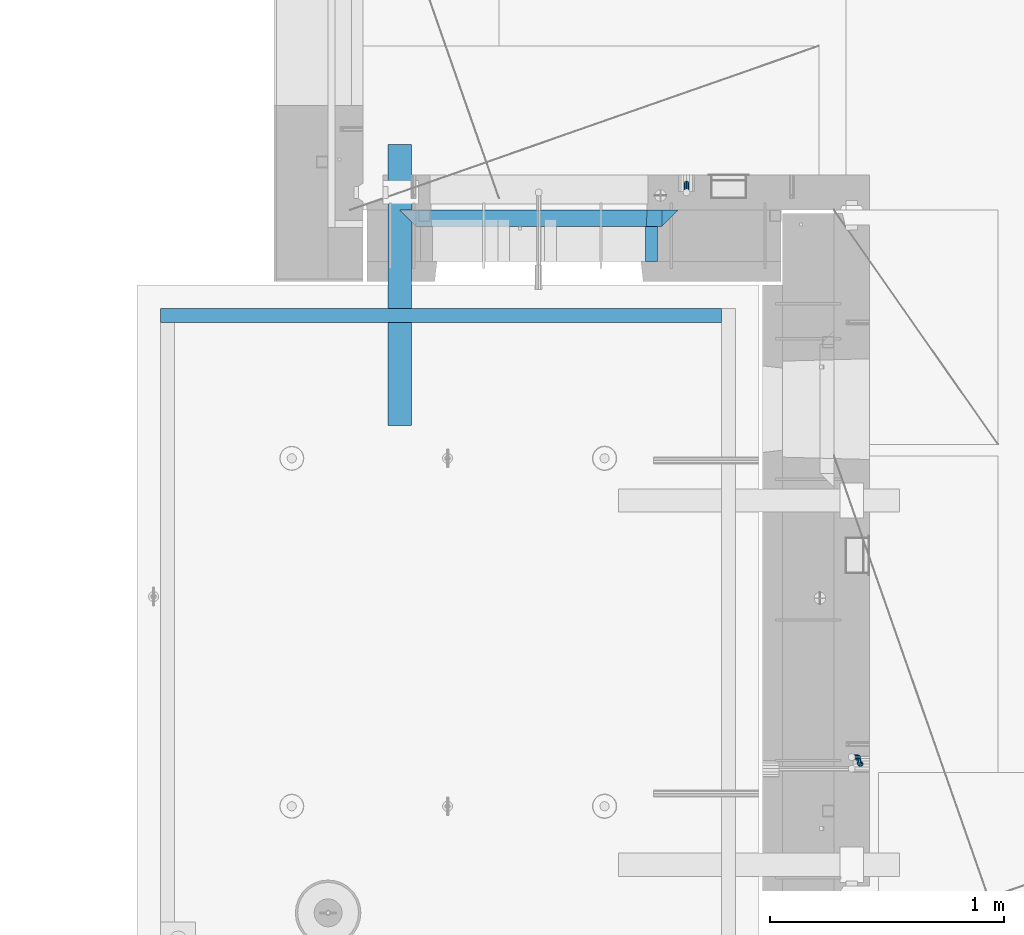
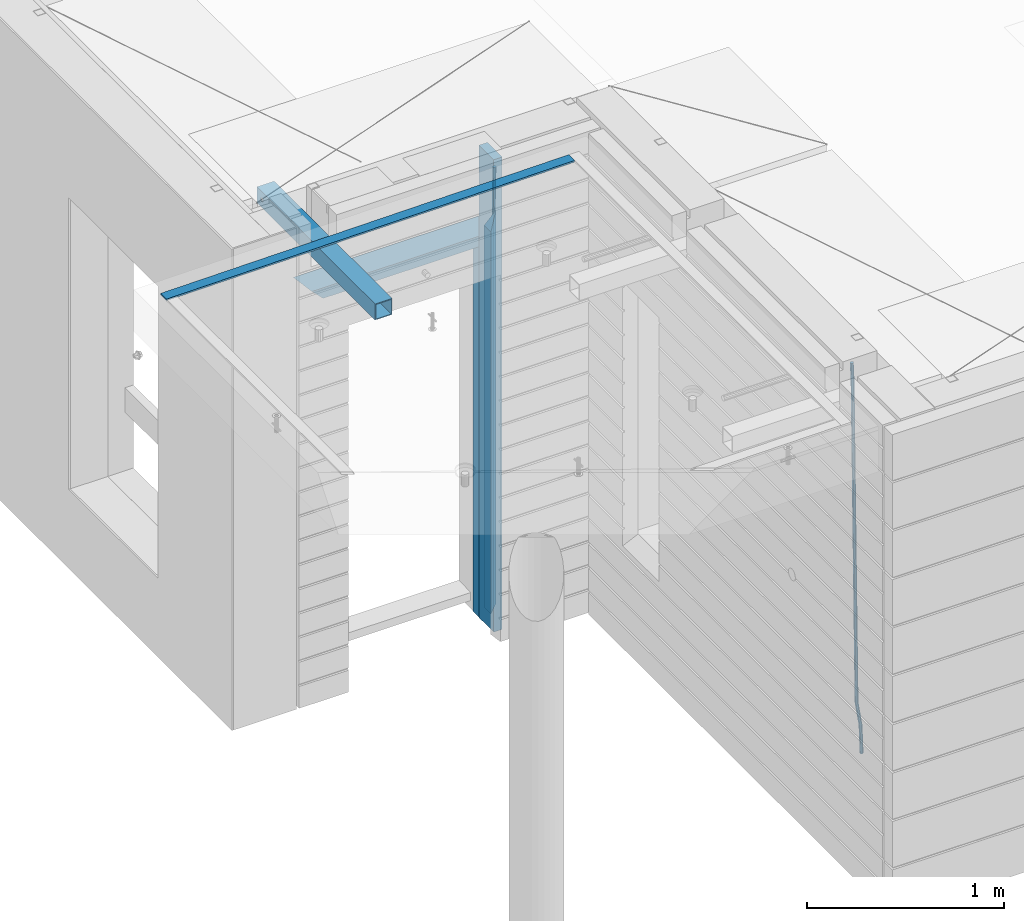
# One storey, part 94 of 350: 9 beams, 4 elements without a shape of their own.
"""IFC2X3 building model written with IfcOpenShell, lengths in millimetres."""

from ifc_helpers import new_model, si_unit, frame, origin_with_axes, place, context, subcontext, project, spatial, faceted_brep, material, type_object, element, aggregate, save


model = new_model("IFC2X3")

# Units and contexts
model_context = context("Model", 3, precision=1e-05, world=origin_with_axes())
body_context = subcontext(model_context, "Body", "Model", "MODEL_VIEW")
ifc_project = project(units=[si_unit("LENGTHUNIT", "METRE", prefix="MILLI"), si_unit("AREAUNIT", "SQUARE_METRE"), si_unit("VOLUMEUNIT", "CUBIC_METRE"), si_unit("MASSUNIT", "GRAM", prefix="KILO"), si_unit("TIMEUNIT", "SECOND"), si_unit("PLANEANGLEUNIT", "RADIAN"), si_unit("SOLIDANGLEUNIT", "STERADIAN"), si_unit("THERMODYNAMICTEMPERATUREUNIT", "DEGREE_CELSIUS"), si_unit("LUMINOUSINTENSITYUNIT", "LUMEN")], contexts=[model_context])

# Site, building, storey
site_placement = place(None, origin_with_axes())
site = spatial("IfcSite", under=ifc_project, at=site_placement, CompositionType="ELEMENT")
building_placement = place(site_placement, origin_with_axes())
building = spatial("IfcBuilding", under=site, at=building_placement, CompositionType="ELEMENT")
storey_placement = place(building_placement, origin_with_axes())
storey = spatial("IfcBuildingStorey", under=building, at=storey_placement, Name="2", CompositionType="ELEMENT", Elevation=0.0)

# Assembly, beams
assembly_1_placement = place(storey_placement, origin_with_axes())
assembly_1 = element("IfcElementAssembly", 1, at=assembly_1_placement, inside=storey, AssemblyPlace="NOTDEFINED", PredefinedType="REINFORCEMENT_UNIT")
ifc_material_1 = material(Name="CONCRETE/C25/30")
beam_type_1 = type_object("IfcBeamType", PredefinedType="NOTDEFINED")
beam_1_placement = place(assembly_1_placement, frame((8155.00084638596, 10914.9999977209, 87160.0), z_axis=(0.0, 0.0, -1.0), x_axis=(1.0, 0.0, 0.0)))
beam_1 = element("IfcBeam", 2, at=beam_1_placement, type_object=beam_type_1, material=ifc_material_1, Name="SK", context=body_context, shape_type="Brep", body=[
    faceted_brep([(70.0000000000164, -35.0, 35.0), (70.0000000000164, 35.0, 35.0), (0.0, -35.0, -35.0), (1189.99771118164, -35.0, -35.0), (1119.99771118163, -35.0, 35.0), (1119.99771118163, 35.0, 35.0)], [[[0, 1, 2]], [[0, 2, 3, 4]], [[1, 0, 4, 5]], [[2, 1, 5, 3]], [[4, 3, 5]]]),
])
beam_2_placement = place(assembly_1_placement, frame((8225.00084638596, 10914.9999988604, 87090.0), z_axis=(0.0, 0.0, -1.0), x_axis=(1.0, 0.0, 0.0)))
beam_2 = element("IfcBeam", 3, at=beam_2_placement, type_object=beam_type_1, material=ifc_material_1, Name="SK", context=body_context, shape_type="Brep", body=[
    faceted_brep([(0.0, -35.0, -35.0), (64.051765297294, -34.9999988604341, 29.0540541156515), (65.9436571275874, 34.9999988604341, 30.9459459459467), (0.0, 35.0, -35.0), (1049.99771118164, -34.9999988604341, -35.0), (985.943657065987, -34.9999988604341, 29.0540541156515), (984.051765235694, 34.9999988604341, 30.9459459459467), (1049.99771118164, 34.9999988604341, -35.0)], [[[0, 1, 2, 3]], [[1, 0, 4, 5]], [[2, 1, 5, 6]], [[3, 2, 6, 7]], [[0, 3, 7, 4]], [[6, 5, 4, 7]]]),
])
beam_3_placement = place(assembly_1_placement, frame((9309.9985575676, 10914.9999977209, 87195.0), z_axis=(-1.0, 3.00000001838171e-08, 0.0), x_axis=(0.0, 0.0, -1.0)))
beam_3 = element("IfcBeam", 4, at=beam_3_placement, type_object=beam_type_1, material=ifc_material_1, Name="SK", context=body_context, shape_type="Brep", body=[
    faceted_brep([(2440.0, -35.0, 35.0), (2440.0, -35.0, -35.0), (2440.0, 35.0, 35.0), (0.0, -35.0, -35.0), (70.0000000000164, 35.0, 35.0), (70.0000000000164, -35.0, 35.0)], [[[0, 1, 2]], [[2, 1, 3, 4]], [[0, 2, 4, 5]], [[1, 0, 5, 3]], [[5, 4, 3]]]),
])
beam_4_placement = place(assembly_1_placement, frame((9239.9985575676, 10914.9999988604, 87125.0), z_axis=(-1.0, 3.00000001838171e-08, 0.0), x_axis=(0.0, 0.0, -1.0)))
beam_4 = element("IfcBeam", 5, at=beam_4_placement, type_object=beam_type_1, material=ifc_material_1, Name="SK", context=body_context, shape_type="Brep", body=[
    faceted_brep([(2370.0, -34.9999988604341, -35.0), (2370.0, 34.9999988604341, -35.0), (2370.0, 34.9999988604341, 30.9459459459467), (2370.0, -34.9999988604341, 29.0540541156515), (0.0, -35.0, -35.0), (0.0, 35.0, -35.0), (65.9459459459467, 34.9999988604341, 30.9459459459467), (64.0540541156515, -34.9999988604341, 29.0540541156533)], [[[0, 1, 2, 3]], [[4, 5, 1, 0]], [[2, 1, 5, 6]], [[3, 2, 6, 7]], [[0, 3, 7, 4]], [[6, 5, 4, 7]]]),
])
ifc_material_2 = material(Name="TIMBER")
beam_type_2 = type_object("IfcBeamType", Name="50X150", PredefinedType="NOTDEFINED")
beam_5_placement = place(assembly_1_placement, frame((9229.9985575676, 10804.9999977209, 87690.0), z_axis=(-1.0, 3.00000001838171e-08, 0.0), x_axis=(0.0, 0.0, -1.0)))
beam_5 = element("IfcBeam", 6, at=beam_5_placement, type_object=beam_type_2, material=ifc_material_2, ObjectType="50X150", context=body_context, shape_type="Brep", body=[
    faceted_brep([(0.0, 75.0, -25.0), (1.81898940354586e-12, 75.0, 25.0), (2930.0, 75.0, 25.0), (2930.0, 75.0, -25.0), (1.81898940354586e-12, -75.0000000000009, 25.0), (2930.0, -75.0, 25.0), (0.0, -75.0, -25.0), (2930.0, -75.0, -25.0)], [[[0, 1, 2, 3]], [[1, 4, 5, 2]], [[4, 6, 7, 5]], [[6, 0, 3, 7]], [[5, 7, 3, 2]], [[6, 4, 1, 0]]]),
])
ifc_material_3 = material()
beam_type_3 = type_object("IfcBeamType", Name="D20", PredefinedType="NOTDEFINED")
beam_6_placement = place(assembly_1_placement, frame((9379.9982799665, 11065.0, 85790.0), z_axis=(0.00020576299992186, -0.999642804629538, -0.0267249099901004), x_axis=(-4.30000201928125e-08, -0.0267249099948059, 0.999642825806181)))
beam_6 = element("IfcBeam", 7, at=beam_6_placement, type_object=beam_type_3, material=ifc_material_3, Name="JM20", ObjectType="D20", context=body_context, shape_type="Brep", body=[
    faceted_brep([(0.0, -10.0, 0.0), (-4.19531716033816e-08, -7.07106781186667, -7.07106781187031), (60.4266690400545, -7.0710677960451, -7.07106780570757), (60.4266690441291, -9.99999998418934, 6.15546014159918e-09), (0.0, 0.0, -10.0), (60.426669036824, 1.58106558956206e-08, -9.99999999384454), (4.196772351861e-08, 7.07106781186303, -7.07106781186667), (60.4266690363438, 7.07106782768096, -7.07106780570757), (0.0, 10.0, 0.0), (60.4266690388904, 10.0000000158179, 6.15182216279209e-09), (4.196772351861e-08, 7.07106781185939, 7.07106781185939), (60.4266690429649, 7.07106782768096, 7.07106781802577), (0.0, 0.0, 10.0), (60.4266690461809, 1.58179318532348e-08, 10.0000000061555), (-4.19531716033816e-08, -7.07106781187031, 7.07106781185939), (60.4266690466611, -7.07106779605238, 7.07106781802213), (61.0378400410118, -7.07106779588503, -7.07106780564936), (60.991799419251, -9.99999998403655, 6.21366780251265e-09), (61.0569027789461, 1.5985278878361e-08, -9.99999999378269), (61.0378209396877, 7.07106782784831, -7.07106780564936), (60.9917724058905, 10.0000000159635, 6.21366780251265e-09), (60.9457317841297, 7.07106782781193, 7.0710678180767), (60.9266690461809, 1.59488990902901e-08, 10.0000000062028), (60.9457508854539, -7.07106779591413, 7.0710678180767), (61.6489592143771, -7.07106614513759, -7.06310863441468), (61.5568818710308, -9.9999984576425, 0.00735959856683621), (61.6870830769039, 1.71821739058942e-06, -9.99179257185824), (61.6489210170112, 7.07106947854481, -7.06310888312146), (61.556827851804, 10.0000015422847, 0.00735924683976918), (61.4647505084577, 7.07106922979438, 7.07782747982128), (61.4266266459163, 1.36643211590126e-06, 10.0065114172685), (61.464788705809, -7.07106639389531, 7.07782772852806), (176.543135720174, -7.07075579406956, -5.56673531796696), (176.451058376813, -9.99968810657447, 1.50373291501455), (176.581259582701, 0.000312069292704109, -8.49541925541052), (176.543097522794, 7.07137982961285, -5.56673556667374), (176.451004357587, 10.00031189336, 1.50373256329476), (176.35892701424, 7.07137958085514, 8.57420079627263), (176.320803151699, 0.000311717507429421, 11.5028847337162), (176.358965211621, -7.07075604281999, 8.57420104497578), (177.098753836006, -7.07075429323595, -5.55949898843028), (176.98362511232, -9.99968666800123, 1.510669025065), (177.146421932586, 0.000313595905026887, -8.48805862247536), (177.098706077581, 7.07138133041735, -5.55949936166144), (176.983557571715, 10.0003133318824, 1.51066849724157), (176.868428848029, 7.07138095712435, 8.58083651073321), (176.820760751449, 0.000313067976094317, 11.5093961447819), (176.868476606425, -7.07075466652896, 8.58083688396073), (177.654312950661, -7.07075204110879, -5.54863964998367), (177.516135294456, -9.99968450931192, 1.52107783331303), (177.711524267797, 0.000315886711177882, -8.47701274570863), (177.654255632195, 7.07138358250813, -5.54864021007961), (177.516054233929, 10.0003154905207, 1.5210770412159), (177.377876577739, 7.0713830223176, 8.59079452451624), (177.320665260588, 0.000315094497636892, 11.5191676202448), (177.377933896176, -7.07075260129932, 8.59079508461218), (299.475681513461, -7.07025820503441, -3.16743615469204), (299.337503857227, -9.99919067323572, 3.9022813287429), (299.532892830684, 0.000809722789199441, -6.09580925047521), (299.475624195184, 7.0718774185807, -3.16743671478434), (299.337422796933, 10.0008093266006, 3.9022805366476), (299.199245140699, 7.07187685839926, 10.9719980200825), (299.142033823475, 0.000808930573839461, 13.9003711158675), (299.199302458976, -7.07025876521584, 10.9719985801767), (300.014932281207, -7.07025601902387, -3.15689559088241), (299.971788958996, -9.99918809853989, 3.91467979818117), (300.032797339853, 0.000811749296190101, -6.08603777550707), (300.014914236686, 7.07187960474585, -3.15689538330298), (299.971753863239, 10.0008119014747, 3.91467990454839), (299.928610539675, 7.07187981509378, 10.9862546943223), (299.910745481058, 0.000812046770079178, 13.9153968789487), (299.92862858421, -7.07025580868321, 10.9862544867447), (300.554271526576, -7.07025682891253, -3.16085443148222), (300.606168552113, -9.999189054608, 3.91002291708173), (300.532783870876, 0.00081099850103783, -6.08970776057868), (300.554292762245, 7.0718787948008, -3.16085451222716), (300.606198583846, 10.0008109453684, 3.9100228028874), (300.658095609382, 7.07187871967653, 10.9809001514495), (300.679583265097, 0.000810892259323737, 13.9097534805496), (300.658074373729, -7.07025690404043, 10.9809002321963), (1493.73308072364, -7.07204854080373, -11.9189871896033), (1493.78497774916, -10.0009807664974, -4.84810984104297), (1493.71159306791, -0.000980713386525167, -14.8478405187034), (1493.7331019593, 7.07008708290959, -11.9189872703519), (1493.7850077809, 9.99901923348079, -4.84810995523549), (1493.83690480642, 7.07008700778533, 2.22276739332847), (1493.85839246215, -0.000980819630058249, 5.15162072242492), (1493.83688357078, -7.07204861592982, 2.22276747407341), (1494.37906755973, -7.07204951083804, -11.9237288414206), (1494.33887067712, -10.0009815982412, -4.85217550811467), (1494.43391396098, -0.000981798046268523, -14.853142475311), (1494.47128160285, 7.07008597443928, -11.9244056328516), (1494.46928102754, 9.99901820595551, -4.85313263573335), (1494.42908414494, 7.07008611855053, 2.2184206975744), (1494.37423774367, -0.000981594239419792, 5.14783433146476), (1494.3368701018, -7.07204936672315, 2.21909748900362), (1495.02495968822, -7.08047207584605, -11.9151326558385), (1494.89268239928, -10.0082034159841, -4.84480482169238), (1495.15612895518, -0.0103996287834889, -14.8435305078528), (1495.20935302251, 7.06046137268277, -11.9145826320491), (1495.15345395346, 9.99009645154365, -4.84402697058613), (1495.02117666451, 7.06236511140742, 2.22630086356003), (1494.89000739757, -0.0077073356587789, 5.15469871557252), (1494.83678333023, -7.07856833711958, 2.22575083976881), (1516.81232084993, -7.36458370639957, -11.6251644217427), (1516.68004356099, -10.292315046534, -4.55483658759658), (1516.94349011689, -0.294511259335195, -14.5535622737552), (1516.99671418422, 6.77634974212924, -11.6246143979515), (1516.94081511517, 9.70598482099194, -4.55405873649033), (1516.80853782622, 6.77825348085389, 2.51626909765582), (1516.67736855928, -0.291818966210485, 5.44466694967014), (1516.62414449194, -7.36267996767492, 2.51571907386642), (1517.44776642873, -7.37287004627251, -11.6167072694061), (1517.34013338278, -10.3009227523598, -4.54605144475318), (1517.52181307798, -0.302052708628253, -14.5458653669793), (1517.51889780765, 6.76954036124152, -11.6176646502499), (1517.44072834359, 9.69946585059188, -4.54740538572696), (1517.33309529764, 6.77141314450637, 2.52325043892597), (1517.2590486484, -0.299404193137889, 5.45240853650103), (1517.26196391872, -7.37099726300949, 2.52420781977162), (1518.08326583009, -7.37099400012448, -11.6084451566603), (1518.00027896308, -10.2989541927, -4.53746177004541), (1518.10018527637, -0.300354896351564, -14.5383632714329), (1518.04112611974, 6.77107862627236, -11.610909819372), (1517.9406844132, 9.70095671561285, -4.54094732948215), (1517.85769754619, 6.77299652303554, 2.53003605713457), (1517.84077809991, -0.297642580735555, 5.45995417190716), (1517.89983725653, -7.36907610336129, 2.53250071984621), (1618.10405127065, -7.07273188347062, -10.3110710264427), (1618.02106440364, -10.0006920760461, -3.24008763982602), (1618.12097071693, -0.00209277969770483, -13.2409891412153), (1618.06191156032, 7.06934074292622, -10.3135356891544), (1617.96146985376, 9.99921883226671, -3.24357319926276), (1617.87848298675, 7.07125863968758, 3.82741018735396), (1617.86156354047, 0.000619535918303882, 6.75732830212473), (1617.92062269709, -7.07081398670744, 3.82987485006379)], [[[0, 1, 2, 3]], [[1, 4, 5, 2]], [[4, 6, 7, 5]], [[6, 8, 9, 7]], [[8, 10, 11, 9]], [[10, 12, 13, 11]], [[12, 14, 15, 13]], [[14, 0, 3, 15]], [[14, 12, 10, 8, 6, 4, 1, 0]], [[3, 2, 16, 17]], [[2, 5, 18, 16]], [[5, 7, 19, 18]], [[7, 9, 20, 19]], [[9, 11, 21, 20]], [[11, 13, 22, 21]], [[13, 15, 23, 22]], [[15, 3, 17, 23]], [[17, 16, 24, 25]], [[16, 18, 26, 24]], [[18, 19, 27, 26]], [[19, 20, 28, 27]], [[20, 21, 29, 28]], [[21, 22, 30, 29]], [[22, 23, 31, 30]], [[23, 17, 25, 31]], [[25, 24, 32, 33]], [[24, 26, 34, 32]], [[26, 27, 35, 34]], [[27, 28, 36, 35]], [[28, 29, 37, 36]], [[29, 30, 38, 37]], [[30, 31, 39, 38]], [[31, 25, 33, 39]], [[33, 32, 40, 41]], [[32, 34, 42, 40]], [[34, 35, 43, 42]], [[35, 36, 44, 43]], [[36, 37, 45, 44]], [[37, 38, 46, 45]], [[38, 39, 47, 46]], [[39, 33, 41, 47]], [[41, 40, 48, 49]], [[40, 42, 50, 48]], [[42, 43, 51, 50]], [[43, 44, 52, 51]], [[44, 45, 53, 52]], [[45, 46, 54, 53]], [[46, 47, 55, 54]], [[47, 41, 49, 55]], [[49, 48, 56, 57]], [[48, 50, 58, 56]], [[50, 51, 59, 58]], [[51, 52, 60, 59]], [[52, 53, 61, 60]], [[53, 54, 62, 61]], [[54, 55, 63, 62]], [[55, 49, 57, 63]], [[57, 56, 64, 65]], [[56, 58, 66, 64]], [[58, 59, 67, 66]], [[59, 60, 68, 67]], [[60, 61, 69, 68]], [[61, 62, 70, 69]], [[62, 63, 71, 70]], [[63, 57, 65, 71]], [[65, 64, 72, 73]], [[64, 66, 74, 72]], [[66, 67, 75, 74]], [[67, 68, 76, 75]], [[68, 69, 77, 76]], [[69, 70, 78, 77]], [[70, 71, 79, 78]], [[71, 65, 73, 79]], [[73, 72, 80, 81]], [[72, 74, 82, 80]], [[74, 75, 83, 82]], [[75, 76, 84, 83]], [[76, 77, 85, 84]], [[77, 78, 86, 85]], [[78, 79, 87, 86]], [[79, 73, 81, 87]], [[81, 80, 88, 89]], [[80, 82, 90, 88]], [[82, 83, 91, 90]], [[83, 84, 92, 91]], [[84, 85, 93, 92]], [[85, 86, 94, 93]], [[86, 87, 95, 94]], [[87, 81, 89, 95]], [[89, 88, 96, 97]], [[88, 90, 98, 96]], [[90, 91, 99, 98]], [[91, 92, 100, 99]], [[92, 93, 101, 100]], [[93, 94, 102, 101]], [[94, 95, 103, 102]], [[95, 89, 97, 103]], [[97, 96, 104, 105]], [[96, 98, 106, 104]], [[98, 99, 107, 106]], [[99, 100, 108, 107]], [[100, 101, 109, 108]], [[101, 102, 110, 109]], [[102, 103, 111, 110]], [[103, 97, 105, 111]], [[105, 104, 112, 113]], [[104, 106, 114, 112]], [[106, 107, 115, 114]], [[107, 108, 116, 115]], [[108, 109, 117, 116]], [[109, 110, 118, 117]], [[110, 111, 119, 118]], [[111, 105, 113, 119]], [[113, 112, 120, 121]], [[112, 114, 122, 120]], [[114, 115, 123, 122]], [[115, 116, 124, 123]], [[116, 117, 125, 124]], [[117, 118, 126, 125]], [[118, 119, 127, 126]], [[119, 113, 121, 127]], [[121, 120, 128, 129]], [[120, 122, 130, 128]], [[122, 123, 131, 130]], [[123, 124, 132, 131]], [[124, 125, 133, 132]], [[125, 126, 134, 133]], [[126, 127, 135, 134]], [[127, 121, 129, 135]], [[130, 131, 132, 133, 134, 135, 129, 128]]]),
])
aggregate(assembly_1, [beam_6, beam_1, beam_2, beam_3, beam_4, beam_5])

# Assembly, beam
assembly_2_placement = place(storey_placement, origin_with_axes())
assembly_2 = element("IfcElementAssembly", 8, at=assembly_2_placement, inside=storey, AssemblyPlace="NOTDEFINED", PredefinedType="REINFORCEMENT_UNIT")
beam_7_placement = place(assembly_2_placement, frame((10125.0000000031, 8585.0017200335, 84989.9999999969), z_axis=(-0.999642804636942, -0.000205726999925762, -0.0267249099902983), x_axis=(-0.0267249099948371, 4.30000201934385e-08, 0.999642825806181)))
beam_7 = element("IfcBeam", 9, at=beam_7_placement, type_object=beam_type_3, material=ifc_material_3, Name="JM20", ObjectType="D20", context=body_context, shape_type="Brep", body=[
    faceted_brep([(0.0, -10.0, 0.0), (-4.19531716033816e-08, -7.07106781186667, -7.07106781187031), (60.4266690400545, -7.0710677960451, -7.07106780570757), (60.4266690441291, -9.99999998418934, 6.15546014159918e-09), (0.0, 0.0, -10.0), (60.426669036824, 1.58106558956206e-08, -9.99999999384454), (4.196772351861e-08, 7.07106781186303, -7.07106781186667), (60.4266690363438, 7.07106782768096, -7.07106780570757), (0.0, 10.0, 0.0), (60.4266690388904, 10.0000000158179, 6.15182216279209e-09), (4.196772351861e-08, 7.07106781185939, 7.07106781185939), (60.4266690429649, 7.07106782768096, 7.07106781802577), (0.0, 0.0, 10.0), (60.4266690461809, 1.58179318532348e-08, 10.0000000061555), (-4.19531716033816e-08, -7.07106781187031, 7.07106781185939), (60.4266690466611, -7.07106779605238, 7.07106781802213), (61.0378400410118, -7.07106779588503, -7.07106780564936), (60.991799419251, -9.99999998403655, 6.21366780251265e-09), (61.0569027789461, 1.5985278878361e-08, -9.99999999378269), (61.0378209396877, 7.07106782784831, -7.07106780564936), (60.9917724058905, 10.0000000159635, 6.21366780251265e-09), (60.9457317841297, 7.07106782781193, 7.0710678180767), (60.9266690461809, 1.59488990902901e-08, 10.0000000062028), (60.9457508854539, -7.07106779591413, 7.0710678180767), (61.6489592143771, -7.07106614513759, -7.06310863441468), (61.5568818710308, -9.9999984576425, 0.00735959856683621), (61.6870830769039, 1.71821739058942e-06, -9.99179257185824), (61.6489210170112, 7.07106947854481, -7.06310888312146), (61.556827851804, 10.0000015422847, 0.00735924683976918), (61.4647505084577, 7.07106922979438, 7.07782747982128), (61.4266266459163, 1.36643211590126e-06, 10.0065114172685), (61.464788705809, -7.07106639389531, 7.07782772852806), (175.37403592006, -7.07075895339585, -5.5819617630732), (175.281958576699, -9.99969126589349, 1.48850647000108), (175.412159782674, 0.000308909964587656, -8.51064570055678), (175.373997722811, 7.07137667028292, -5.58196201177816), (175.281904557633, 10.0003087340338, 1.48850611827766), (175.189827214257, 7.07137642153248, 8.55897435135012), (175.151703351657, 0.000308558175674989, 11.4876582888337), (175.189865411507, -7.07075920214811, 8.55897460005508), (177.947973008238, -7.07075200072177, -5.54843899804655), (178.185320525896, -9.99968342338434, 1.52631963989006), (177.145703789589, 0.000313592583552236, -8.48806815245916), (176.248471297557, 7.07137903239709, -5.57057293303842), (175.781862157353, 10.0003100845097, 1.49501752883771), (176.019209675011, 7.07137866184712, 8.56977616677796), (176.82147889366, 0.000313068545438, 11.5094053211888), (177.718711385693, -7.07075237127174, 8.59191010176619), (180.448353003565, -6.46083449902471, -5.49969035980757), (181.005711191348, -9.31170574331372, 1.58130736355633), (178.829707169425, 0.411092408678087, -8.45523599426269), (177.097954465877, 7.27859339690076, -5.55401099135815), (176.267532139987, 10.118779526354, 1.50448638970374), (176.824890327771, 7.26790828206686, 8.58548411306947), (178.443536161911, 0.395981374362236, 11.5410297475228), (180.175288865445, -6.47151961386044, 8.63980474461823), (300.130679507536, 22.7332662835124, -3.16630485466521), (300.688037695305, 19.8823950392234, 3.91469286870233), (298.512033673396, 29.6051931912152, -6.12185048911851), (296.780280969833, 36.4726941794397, -3.22062548621216), (295.949858643944, 39.312880308893, 3.83787189484792), (296.507216831713, 36.462009064604, 10.9188696182155), (298.125862665867, 29.5900821569012, 13.8744152526688), (299.85761536943, 22.7225811686749, 10.9731902497624), (300.838254221671, 22.9058649296021, -3.15250963000472), (301.173707677939, 20.0008644810696, 3.92416172956655), (299.995227641819, 29.9669885828916, -6.09293340998011), (299.138461475406, 37.0479249704349, -3.1746492391685), (298.769837722954, 40.0007575907111, 3.89285159402425), (299.105291179221, 37.0957571421768, 10.9695229535973), (299.948317759059, 30.0346334888854, 13.9099467335673), (300.805083925487, 22.9536971013422, 10.9916625627593), (301.566623170889, 22.9058626555343, -3.16352102199562), (301.673650550176, 20.0008629201784, 3.91660365485041), (301.522009776192, 29.9669838160717, -6.1160151140848), (301.565944287635, 37.0479173915064, -3.21134762509791), (301.672690464271, 40.0007485276092, 3.84896662410392), (301.779717843558, 37.0957487922533, 10.9290913009499), (301.82433123824, 30.0346276317159, 13.881585393041), (301.780396726797, 22.953694056283, 10.9769179040522), (2293.36508471855, 22.8996439899911, -33.2752846422391), (2293.47211209782, 19.9946442546316, -26.195159965393), (2293.32047132387, 29.9607651505266, -36.2277787343282), (2293.36440583531, 37.0416987259578, -33.3231112453414), (2293.47115201195, 39.9945298620642, -26.2627969961413), (2293.5781793912, 37.0895301267083, -19.1826723192917), (2293.6227927859, 30.0284089661727, -16.2301782272025), (2293.57885827446, 22.947475390738, -19.134845716193), (2294.06569143596, 22.8996418025999, -33.2858763282329), (2294.05315457586, 19.9946424405407, -26.2039440939534), (2294.10906780435, 29.9607626884226, -36.2397006387127), (2294.15787439278, 37.0416962486433, -33.3351068051852), (2294.18352096362, 39.9945276379531, -26.2735665021428), (2294.17098410353, 37.089528275892, -19.1916342678614), (2294.12760773512, 30.0284073900693, -16.2378099573798), (2294.07880114671, 22.9474738298504, -19.1424037909092), (2294.76625661059, 22.8905062380709, -33.2765524984534), (2294.63416260075, 19.9870659344633, -26.1962114516227), (2294.89761752472, 29.9504797809677, -36.2292058216281), (2294.95129590121, 37.0313498117212, -33.3245471494174), (2294.8958476751, 39.9852386997136, -26.2640861379368), (2294.76375366526, 37.0817983961042, -19.1837450911044), (2294.63239275114, 30.0218248532074, -16.2310917679315), (2294.57871437464, 22.9409548224558, -19.135750440144), (2316.52593703129, 22.6067539594387, -32.9869526673174), (2316.39384302145, 19.7033136558293, -25.9066116204867), (2316.65729794541, 29.6667275023337, -35.9396059904902), (2316.71097632191, 36.7475975330854, -33.0349473182796), (2316.6555280958, 39.7014864210796, -25.974486306799), (2316.52343408595, 36.798046117472, -18.8941452599665), (2316.39207317181, 29.7380725745734, -15.9414919367919), (2316.33839479534, 22.6572025438199, -18.8461506090043), (2317.16158675382, 22.5984649104412, -32.9784927980199), (2317.05394423746, 19.6947057525631, -25.8978263259869), (2317.23590155228, 29.6591823505332, -35.931905348587), (2317.23335603178, 36.740785556527, -33.0279949608521), (2317.15544132373, 39.6949674136868, -25.967832956032), (2317.04779880737, 36.7912082558087, -18.887166483999), (2316.97348400892, 29.730490815713, -15.9337539334319), (2316.97602952941, 22.648887609721, -18.8376643211668), (2317.79729034709, 22.6003447382427, -32.9702310967514), (2317.71410127044, 19.6966744277033, -25.8892409069249), (2317.81455440674, 29.660885407864, -35.9243995360212), (2317.75578039732, 36.7423274699941, -33.021234418542), (2317.65539733646, 39.6964582057935, -25.9613704963267), (2317.57220825978, 36.7927878952578, -18.8803803065002), (2317.55494420015, 29.7322472256365, -15.9262118672305), (2317.6137182096, 22.6508051635028, -18.8293769847114), (2417.81807008978, 22.8986075784269, -31.6728570405921), (2417.73488101311, 19.9949372678893, -24.5918668507657), (2417.83533414939, 29.9591482480482, -34.6270254798619), (2417.77656013996, 37.0405903101819, -31.7238603623846), (2417.67617707912, 39.9947210459814, -24.6639964401675), (2417.59298800245, 37.0910507354438, -17.5830062503428), (2417.57572394283, 30.0305100658206, -14.628837811073), (2417.63449795225, 22.9490680036906, -17.5320029285504)], [[[0, 1, 2, 3]], [[1, 4, 5, 2]], [[4, 6, 7, 5]], [[6, 8, 9, 7]], [[8, 10, 11, 9]], [[10, 12, 13, 11]], [[12, 14, 15, 13]], [[14, 0, 3, 15]], [[14, 12, 10, 8, 6, 4, 1, 0]], [[3, 2, 16, 17]], [[2, 5, 18, 16]], [[5, 7, 19, 18]], [[7, 9, 20, 19]], [[9, 11, 21, 20]], [[11, 13, 22, 21]], [[13, 15, 23, 22]], [[15, 3, 17, 23]], [[17, 16, 24, 25]], [[16, 18, 26, 24]], [[18, 19, 27, 26]], [[19, 20, 28, 27]], [[20, 21, 29, 28]], [[21, 22, 30, 29]], [[22, 23, 31, 30]], [[23, 17, 25, 31]], [[25, 24, 32, 33]], [[24, 26, 34, 32]], [[26, 27, 35, 34]], [[27, 28, 36, 35]], [[28, 29, 37, 36]], [[29, 30, 38, 37]], [[30, 31, 39, 38]], [[31, 25, 33, 39]], [[33, 32, 40, 41]], [[32, 34, 42, 40]], [[34, 35, 43, 42]], [[35, 36, 44, 43]], [[36, 37, 45, 44]], [[37, 38, 46, 45]], [[38, 39, 47, 46]], [[39, 33, 41, 47]], [[41, 40, 48, 49]], [[40, 42, 50, 48]], [[42, 43, 51, 50]], [[43, 44, 52, 51]], [[44, 45, 53, 52]], [[45, 46, 54, 53]], [[46, 47, 55, 54]], [[47, 41, 49, 55]], [[49, 48, 56, 57]], [[48, 50, 58, 56]], [[50, 51, 59, 58]], [[51, 52, 60, 59]], [[52, 53, 61, 60]], [[53, 54, 62, 61]], [[54, 55, 63, 62]], [[55, 49, 57, 63]], [[57, 56, 64, 65]], [[56, 58, 66, 64]], [[58, 59, 67, 66]], [[59, 60, 68, 67]], [[60, 61, 69, 68]], [[61, 62, 70, 69]], [[62, 63, 71, 70]], [[63, 57, 65, 71]], [[65, 64, 72, 73]], [[64, 66, 74, 72]], [[66, 67, 75, 74]], [[67, 68, 76, 75]], [[68, 69, 77, 76]], [[69, 70, 78, 77]], [[70, 71, 79, 78]], [[71, 65, 73, 79]], [[73, 72, 80, 81]], [[72, 74, 82, 80]], [[74, 75, 83, 82]], [[75, 76, 84, 83]], [[76, 77, 85, 84]], [[77, 78, 86, 85]], [[78, 79, 87, 86]], [[79, 73, 81, 87]], [[81, 80, 88, 89]], [[80, 82, 90, 88]], [[82, 83, 91, 90]], [[83, 84, 92, 91]], [[84, 85, 93, 92]], [[85, 86, 94, 93]], [[86, 87, 95, 94]], [[87, 81, 89, 95]], [[89, 88, 96, 97]], [[88, 90, 98, 96]], [[90, 91, 99, 98]], [[91, 92, 100, 99]], [[92, 93, 101, 100]], [[93, 94, 102, 101]], [[94, 95, 103, 102]], [[95, 89, 97, 103]], [[97, 96, 104, 105]], [[96, 98, 106, 104]], [[98, 99, 107, 106]], [[99, 100, 108, 107]], [[100, 101, 109, 108]], [[101, 102, 110, 109]], [[102, 103, 111, 110]], [[103, 97, 105, 111]], [[105, 104, 112, 113]], [[104, 106, 114, 112]], [[106, 107, 115, 114]], [[107, 108, 116, 115]], [[108, 109, 117, 116]], [[109, 110, 118, 117]], [[110, 111, 119, 118]], [[111, 105, 113, 119]], [[113, 112, 120, 121]], [[112, 114, 122, 120]], [[114, 115, 123, 122]], [[115, 116, 124, 123]], [[116, 117, 125, 124]], [[117, 118, 126, 125]], [[118, 119, 127, 126]], [[119, 113, 121, 127]], [[121, 120, 128, 129]], [[120, 122, 130, 128]], [[122, 123, 131, 130]], [[123, 124, 132, 131]], [[124, 125, 133, 132]], [[125, 126, 134, 133]], [[126, 127, 135, 134]], [[127, 121, 129, 135]], [[130, 131, 132, 133, 134, 135, 129, 128]]]),
])
aggregate(assembly_2, [beam_7])

# Assemblies, beams
assembly_3_placement = place(storey_placement, origin_with_axes())
assembly_3 = element("IfcElementAssembly", 10, at=assembly_3_placement, inside=storey, AssemblyPlace="NOTDEFINED", PredefinedType="REINFORCEMENT_UNIT")
assembly_4_placement = place(assembly_3_placement, origin_with_axes())
assembly_4 = element("IfcElementAssembly", 11, at=assembly_4_placement, AssemblyPlace="NOTDEFINED", PredefinedType="NOTDEFINED")
ifc_material_4 = material(Name="Undefined/350")
beam_type_4 = type_object("IfcBeamType", Name="100X100X5", PredefinedType="NOTDEFINED")
beam_8_placement = place(assembly_4_placement, frame((8154.95985679893, 10029.9865573969, 87555.0), z_axis=(0.0, 0.0, 1.0), x_axis=(2.22429999942101e-05, 0.999999999752625, 0.0)))
beam_8 = element("IfcBeam", 12, at=beam_8_placement, type_object=beam_type_4, material=ifc_material_4, ObjectType="100X100X5", context=body_context, shape_type="Brep", body=[
    faceted_brep([(1160.82642950046, -49.9743978761207, -6.25), (1160.82642783901, -44.9999999999991, -6.25), (1156.25111029171, -44.9999999999991, -10.8253175473074), (1156.25111195316, -49.9743994042774, -10.8253175473074), (1150.00111029171, -44.9999999999991, -12.5), (1150.00111195316, -49.9744014917787, -12.5), (1143.75111029171, -44.9999999999991, -10.8253175473074), (1143.75111195316, -49.9744035792783, -10.8253175473074), (1139.1757927444, -44.9999999999991, -6.25), (1139.17579440585, -49.9744051074349, -6.25), (1137.50111029171, -44.9999999999991, 0.0), (1137.50111195316, -49.9744056667778, 0.0), (1139.1757927444, -44.9999999999991, 6.25), (1139.17579440585, -49.9744051074349, 6.25), (1143.75111029171, -44.9999999999991, 10.8253175473074), (1143.75111195316, -49.9744035792783, 10.8253175473074), (1150.00111029171, -44.9999999999991, 12.5), (1150.00111195316, -49.9744014917787, 12.5), (1156.25111029171, -44.9999999999991, 10.8253175473074), (1156.25111195316, -49.9743994042774, 10.8253175473074), (1160.82642783901, -44.9999999999991, 6.25), (1160.82642950046, -49.9743978761207, 6.25), (1162.50111029171, -44.9999999999991, 0.0), (1162.50111195316, -49.9743973167779, 0.0), (1160.82639777901, 44.9999999999982, -6.25), (1160.82639610046, 50.0256021227788, -6.25), (1156.25107855315, 50.0256005946221, -10.8253175473074), (1156.2510802317, 44.9999999999982, -10.8253175473074), (1150.00107855316, 50.0255985071226, -12.5), (1150.00108023171, 44.9999999999982, -12.5), (1143.75107855316, 50.0255964196231, -10.8253175473074), (1143.75108023171, 44.9999999999982, -10.8253175473074), (1139.17576100585, 50.0255948914664, -6.25), (1139.1757626844, 44.9999999999982, -6.25), (1137.50107855316, 50.0255943321226, 0.0), (1137.5010802317, 44.9999999999982, 0.0), (1139.17576100585, 50.0255948914664, 6.25), (1139.1757626844, 44.9999999999982, 6.25), (1143.75107855316, 50.0255964196231, 10.8253175473074), (1143.75108023171, 44.9999999999982, 10.8253175473074), (1150.00107855316, 50.0255985071226, 12.5), (1150.00108023171, 44.9999999999982, 12.5), (1156.25107855315, 50.0256005946221, 10.8253175473074), (1156.2510802317, 44.9999999999982, 10.8253175473074), (1160.82639610046, 50.0256021227788, 6.25), (1160.82639777901, 44.9999999999982, 6.25), (1162.50107855316, 50.0256026821226, 0.0), (1162.50108023171, 44.9999999999982, 0.0), (1.81898940354586e-12, -50.0000000000009, -50.0), (1.81898940354586e-12, 49.9999999999991, -50.0), (1200.00449189278, 49.9999999999982, -50.0), (1200.00449189278, -50.0000000000009, -50.0), (1.81898940354586e-12, -50.0000000000009, 50.0), (1200.00449189278, -50.0000000000009, 50.0), (1.81898940354586e-12, 49.9999999999991, 50.0), (1200.00449189278, 49.9999999999982, 50.0), (0.0, 44.9999999999991, 45.0), (1.81898940354586e-12, -45.0000000000009, 45.0), (1.81898940354586e-12, -45.0000000000009, -45.0), (0.0, 44.9999999999991, -45.0), (1200.00449189278, 44.9999999999982, -45.0), (1200.00449189278, 44.9999999999982, 45.0), (1200.00449189278, -45.0000000000009, 45.0), (1200.00449189278, -45.0000000000009, -45.0)], [[[0, 1, 2, 3]], [[3, 2, 4, 5]], [[5, 4, 6, 7]], [[7, 6, 8, 9]], [[9, 8, 10, 11]], [[11, 10, 12, 13]], [[13, 12, 14, 15]], [[15, 14, 16, 17]], [[17, 16, 18, 19]], [[19, 18, 20, 21]], [[21, 20, 22, 23]], [[23, 22, 1, 0]], [[24, 25, 26, 27]], [[27, 26, 28, 29]], [[29, 28, 30, 31]], [[31, 30, 32, 33]], [[33, 32, 34, 35]], [[35, 34, 36, 37]], [[37, 36, 38, 39]], [[39, 38, 40, 41]], [[41, 40, 42, 43]], [[43, 42, 44, 45]], [[45, 44, 46, 47]], [[47, 46, 25, 24]], [[48, 49, 50, 51]], [[52, 48, 51, 53], [3, 5, 7, 9, 11, 13, 15, 17, 19, 21, 23, 0]], [[54, 52, 53, 55]], [[48, 52, 54, 49], [56, 57, 58, 59]], [[56, 59, 60, 61], [27, 29, 31, 33, 35, 37, 39, 41, 43, 45, 47, 24]], [[57, 56, 61, 62]], [[58, 57, 62, 63], [18, 16, 14, 12, 10, 8, 6, 4, 2, 1, 22, 20]], [[59, 58, 63, 60]], [[53, 51, 50, 55], [62, 61, 60, 63]], [[49, 54, 55, 50], [42, 40, 38, 36, 34, 32, 30, 28, 26, 25, 46, 44]]]),
])
aggregate(assembly_4, [beam_8])
ifc_material_5 = material(Name="CONCRETE/Concrete_Undefined")
beam_type_5 = type_object("IfcBeamType", PredefinedType="NOTDEFINED")
beam_9_placement = place(assembly_3_placement, frame((9529.73225763201, 10500.0586098955, 87724.6636624749), z_axis=(-0.00918619300035676, -2.22000000585005e-07, 0.99995780603889), x_axis=(-0.999957805748064, -2.41189999941813e-05, -0.00918619299768504)))
beam_9 = element("IfcBeam", 13, at=beam_9_placement, type_object=beam_type_5, material=ifc_material_5, context=body_context, shape_type="Brep", body=[
    faceted_brep([(2.5465851649642e-11, 29.9999999999982, -4.99999999998545), (-2.91038304567337e-11, 29.9999999999982, 5.0), (2394.89682739776, 29.9999999999964, 5.0), (2394.89682739781, 30.0, -4.99999999998545), (-2.5465851649642e-11, -30.0000000000018, 5.0), (2394.89682739776, -30.0000000000036, 5.0), (2.72848410531878e-11, -30.0000000000018, -4.99999999998545), (2394.89682739781, -30.0, -4.99999999998545)], [[[0, 1, 2, 3]], [[1, 4, 5, 2]], [[4, 6, 7, 5]], [[6, 0, 3, 7]], [[5, 7, 3, 2]], [[6, 4, 1, 0]]]),
])
aggregate(assembly_3, [beam_9, assembly_4])

save(model, "model.ifc")
